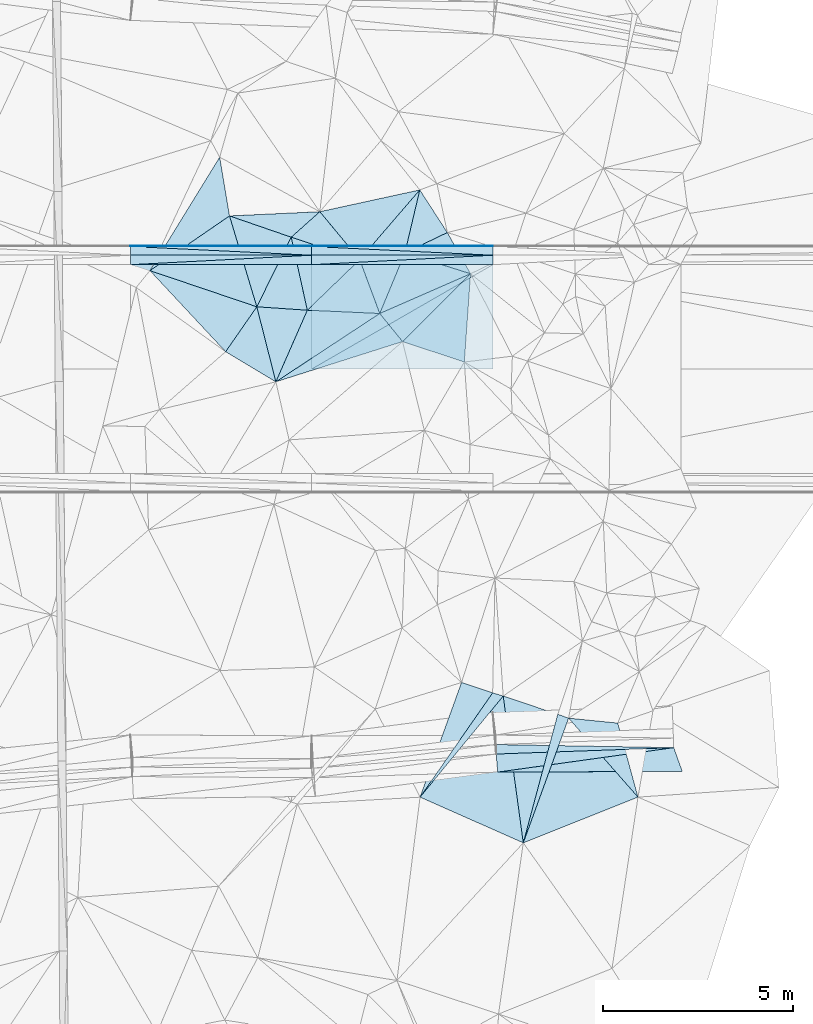
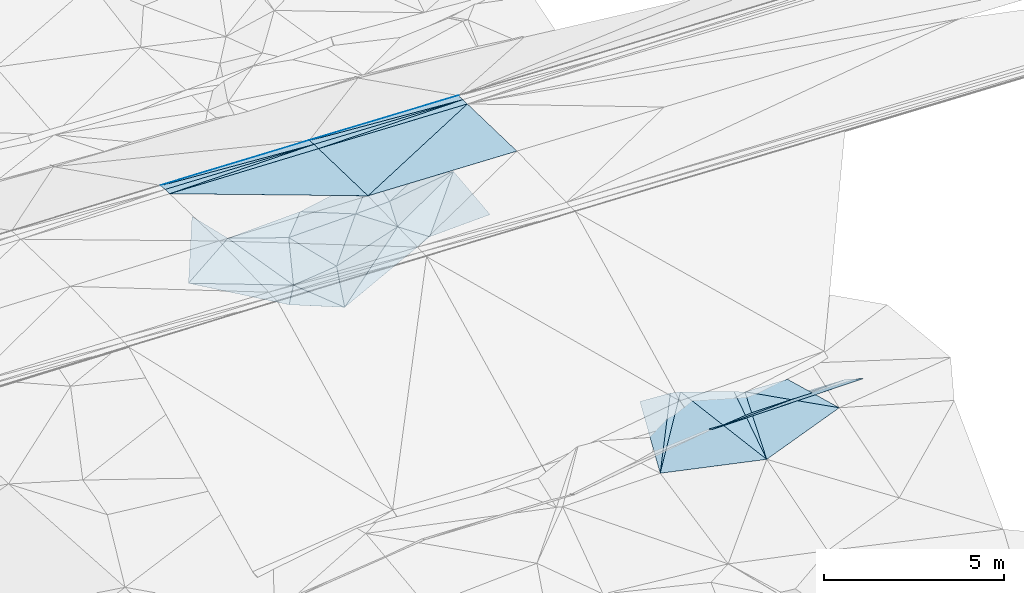
# One storey, part 104 of 275: 46 plates.
"""IFC2X3 building model written with IfcOpenShell, lengths in millimetres."""

from ifc_helpers import new_model, si_unit, frame, origin_with_axes, place, context, subcontext, project, spatial, polyline, outline, extrude, material, type_object, element, save


model = new_model("IFC2X3")

# Units and contexts
model_context = context("Model", 3, precision=1e-05, world=origin_with_axes())
body_context = subcontext(model_context, "Body", "Model", "MODEL_VIEW")
ifc_project = project(units=[si_unit("LENGTHUNIT", "METRE", prefix="MILLI"), si_unit("AREAUNIT", "SQUARE_METRE"), si_unit("VOLUMEUNIT", "CUBIC_METRE"), si_unit("MASSUNIT", "GRAM", prefix="KILO"), si_unit("TIMEUNIT", "SECOND"), si_unit("PLANEANGLEUNIT", "RADIAN"), si_unit("SOLIDANGLEUNIT", "STERADIAN"), si_unit("THERMODYNAMICTEMPERATUREUNIT", "DEGREE_CELSIUS"), si_unit("LUMINOUSINTENSITYUNIT", "LUMEN")], contexts=[model_context])

# Site, building, storey
site_placement = place(None, origin_with_axes())
site = spatial("IfcSite", under=ifc_project, at=site_placement, CompositionType="ELEMENT")
building_placement = place(site_placement, origin_with_axes())
building = spatial("IfcBuilding", under=site, at=building_placement, Name="Undefined", CompositionType="ELEMENT")
storey_placement = place(building_placement, origin_with_axes())
storey = spatial("IfcBuildingStorey", under=building, at=storey_placement, Name="Undefined", CompositionType="ELEMENT", Elevation=0.0)

# Plates
ifc_material = material()
plate_type_1 = type_object("IfcPlateType", PredefinedType="NOTDEFINED")
plate_1_placement = place(storey_placement, frame((-34157.7798886638, 63288.8349847427, 48159.3554211649), z_axis=(-0.0325349900325498, -0.0249770971322937, -0.999158455422575), x_axis=(-0.999470311448704, 5.72619769427513e-05, 0.0325437129672813)))
element("IfcPlate", 1, at=plate_1_placement, inside=storey, type_object=plate_type_1, material=ifc_material, Name="00_PR", context=body_context, shape_type="SweptSolid", body=[
    extrude(outline(polyline([(0.0, 0.0), (4774.68701171875, -1.00262695923448e-08), (-2.23709058761597, 2750.8583984375), (0.0, 0.0)])), frame((-8.85201319254618e-08, 2.18876761149539e-07, -0.5000001331573), z_axis=(0.0, 0.0, 1.0), x_axis=(1.0, 0.0, 0.0)), (0.0, 0.0, 1.0), 1.0),
])
plate_2_placement = place(storey_placement, frame((-38929.7788829464, 66039.1084148734, 48245.9914218387), z_axis=(-0.0325349900325498, -0.0249770971322937, -0.999158455422575), x_axis=(0.999470311737321, -5.73689731605573e-05, -0.0325437039149539)))
element("IfcPlate", 2, at=plate_2_placement, inside=storey, type_object=plate_type_1, material=ifc_material, Name="00_PR", context=body_context, shape_type="SweptSolid", body=[
    extrude(outline(polyline([(0.0, 0.0), (4774.685546875, -1.0550138540566e-08), (-2.23870348930359, 2750.85791015625), (0.0, 0.0)])), frame((-8.85201319254618e-08, 2.18876761149539e-07, -0.5000001331573), z_axis=(0.0, 0.0, 1.0), x_axis=(1.0, 0.0, 0.0)), (0.0, 0.0, 1.0), 1.0),
])
plate_3_placement = place(storey_placement, frame((-43701.9354299348, 66039.382331575, 48388.7053802406), z_axis=(-0.0298842901449347, -0.024979317513143, -0.999241193555946), x_axis=(0.999553126962381, -5.74589773414719e-05, -0.0298921909232467)))
element("IfcPlate", 3, at=plate_3_placement, inside=storey, type_object=plate_type_1, material=ifc_material, Name="00_PR", context=body_context, shape_type="SweptSolid", body=[
    extrude(outline(polyline([(0.0, 0.0), (4774.29150390625, 1.48138497024775e-08), (4772.2353515625, 2750.85791015625), (0.0, 0.0)])), frame((-8.85201319254618e-08, 2.18876761149539e-07, -0.5000001331573), z_axis=(0.0, 0.0, 1.0), x_axis=(1.0, 0.0, 0.0)), (0.0, 0.0, 1.0), 1.0),
])
plate_type_2 = type_object("IfcPlateType", PredefinedType="NOTDEFINED")
plate_4_placement = place(storey_placement, frame((-29391.4771002406, 53320.1885323765, 44802.106068537), z_axis=(-0.0159420009922025, 0.0032903428272256, -0.999867504346673), x_axis=(-0.999226396124038, -0.0360076280313883, 0.0158132859494789)))
element("IfcPlate", 4, at=plate_4_placement, inside=storey, type_object=plate_type_2, material=ifc_material, Name="00_PR", context=body_context, shape_type="SweptSolid", body=[
    extrude(outline(polyline([(0.0, 0.0), (4679.5458984375, -6.95581547915936e-09), (4674.77392578125, 250.001678466797), (0.0, 0.0)])), frame((-8.85201319254618e-08, 2.18876761149539e-07, -0.5000001331573), z_axis=(0.0, 0.0, 1.0), x_axis=(1.0, 0.0, 0.0)), (0.0, 0.0, 1.0), 1.0),
])
plate_5_placement = place(storey_placement, frame((-34157.6080068169, 66288.8350087851, 48084.3554223276), z_axis=(-0.0325349900325498, -0.0249770971322937, -0.999158455422575), x_axis=(-5.7277968073799e-05, -0.999687644772795, 0.0249921909375039)))
element("IfcPlate", 5, at=plate_5_placement, inside=storey, type_object=plate_type_2, material=ifc_material, Name="00_PR", context=body_context, shape_type="SweptSolid", body=[
    extrude(outline(polyline([(0.0, 0.0), (250.078109741211, 1.02591002359986e-09), (253.961563110352, 4774.68408203125), (0.0, 0.0)])), frame((-8.85201319254618e-08, 2.18876761149539e-07, -0.5000001331573), z_axis=(0.0, 0.0, 1.0), x_axis=(1.0, 0.0, 0.0)), (0.0, 0.0, 1.0), 1.0),
])
for number, where, z_axis, x_axis, name in (
    (6, (-38929.7632344316, 66289.1084149121, 48239.7413805011), (-0.0298842901449347, -0.024979317513143, -0.999241193555946), (-5.7277968073799e-05, -0.999687644772795, 0.0249921909375039), "00_PR"),
    (7, (-43701.9354299348, 66039.382331575, 48388.7053802406), (-0.0298842901449347, -0.024979317513143, -0.999241193555946), (5.72779774420735e-05, 0.999687644773175, -0.0249921909222736), "00_PR"),
):
    element("IfcPlate", number, at=place(storey_placement, frame(where, z_axis=z_axis, x_axis=x_axis)), inside=storey, type_object=plate_type_2, material=ifc_material, Name=name, context=body_context, shape_type="SweptSolid", body=[
        extrude(outline(polyline([(0.0, 0.0), (250.078109741211, 1.02591002359986e-09), (253.644332885742, 4774.2900390625), (0.0, 0.0)])), frame((-8.85201319254618e-08, 2.18876761149539e-07, -0.5000001331573), z_axis=(0.0, 0.0, 1.0), x_axis=(1.0, 0.0, 0.0)), (0.0, 0.0, 1.0), 1.0),
    ])
plate_6_placement = place(storey_placement, frame((-38929.7788829464, 66039.1084148734, 48245.9914218387), z_axis=(-0.0325349900325498, -0.0249770971322937, -0.999158455422575), x_axis=(5.72779774420735e-05, 0.999687644773175, -0.0249921909222736)))
element("IfcPlate", 8, at=plate_6_placement, inside=storey, type_object=plate_type_2, material=ifc_material, Name="00_PR", context=body_context, shape_type="SweptSolid", body=[
    extrude(outline(polyline([(0.0, 0.0), (250.078109741211, 1.02591002359986e-09), (253.961563110352, 4774.68408203125), (0.0, 0.0)])), frame((-8.85201319254618e-08, 2.18876761149539e-07, -0.5000001331573), z_axis=(0.0, 0.0, 1.0), x_axis=(1.0, 0.0, 0.0)), (0.0, 0.0, 1.0), 1.0),
])
plate_type_3 = type_object("IfcPlateType", PredefinedType="NOTDEFINED")
plate_7_placement = place(storey_placement, frame((-34157.5936662457, 66538.822543624, 48071.8558900314), z_axis=(-0.032506019804462, -0.0499086502594823, -0.998224666748798), x_axis=(-5.44309877651753e-05, -0.998752377894856, 0.0499368069327535)))
element("IfcPlate", 9, at=plate_7_placement, inside=storey, type_object=plate_type_3, material=ifc_material, Name="00_PR", context=body_context, shape_type="SweptSolid", body=[
    extrude(outline(polyline([(0.0, 0.0), (20.0253086090088, -9.45874489843845e-11), (27.770565032959, 4774.6796875), (0.0, 0.0)])), frame((-8.85201319254618e-08, 2.18876761149539e-07, -0.5000001331573), z_axis=(0.0, 0.0, 1.0), x_axis=(1.0, 0.0, 0.0)), (0.0, 0.0, 1.0), 1.0),
])
plate_8_placement = place(storey_placement, frame((-38929.7488949328, 66539.0959489802, 48227.2418485083), z_axis=(-0.029857778963741, -0.0499145954196307, -0.998307090127806), x_axis=(-7.46349832174646e-05, -0.998752262639263, 0.0499390859204745)))
element("IfcPlate", 10, at=plate_8_placement, inside=storey, type_object=plate_type_3, material=ifc_material, Name="00_PR", context=body_context, shape_type="SweptSolid", body=[
    extrude(outline(polyline([(0.0, 0.0), (20.0243949890137, 1.30967237055302e-10), (27.2349071502686, 4774.28564453125), (0.0, 0.0)])), frame((-8.85201319254618e-08, 2.18876761149539e-07, -0.5000001331573), z_axis=(0.0, 0.0, 1.0), x_axis=(1.0, 0.0, 0.0)), (0.0, 0.0, 1.0), 1.0),
])
plate_9_placement = place(storey_placement, frame((-38929.7517155213, 66519.0965410612, 48228.2418896468), z_axis=(-0.0325060109705526, -0.049910272192996, -0.998224585942664), x_axis=(7.46349675932083e-05, 0.998752262639191, -0.0499390859219244)))
element("IfcPlate", 11, at=plate_9_placement, inside=storey, type_object=plate_type_3, material=ifc_material, Name="00_PR", context=body_context, shape_type="SweptSolid", body=[
    extrude(outline(polyline([(0.0, 0.0), (20.0243949890137, 1.30967237055302e-10), (27.8673305511475, 4774.67919921875), (0.0, 0.0)])), frame((-8.85201319254618e-08, 2.18876761149539e-07, -0.5000001331573), z_axis=(0.0, 0.0, 1.0), x_axis=(1.0, 0.0, 0.0)), (0.0, 0.0, 1.0), 1.0),
])
plate_10_placement = place(storey_placement, frame((-43701.907858217, 66519.3695432309, 48370.9558479757), z_axis=(-0.0298577808993792, -0.049913563424443, -0.998307141668354), x_axis=(5.4430974321816e-05, 0.998752377894704, -0.0499368069357979)))
element("IfcPlate", 12, at=plate_10_placement, inside=storey, type_object=plate_type_3, material=ifc_material, Name="00_PR", context=body_context, shape_type="SweptSolid", body=[
    extrude(outline(polyline([(0.0, 0.0), (20.0253086090088, -9.45874489843845e-11), (27.1381683349609, 4774.2861328125), (0.0, 0.0)])), frame((-8.85201319254618e-08, 2.18876761149539e-07, -0.5000001331573), z_axis=(0.0, 0.0, 1.0), x_axis=(1.0, 0.0, 0.0)), (0.0, 0.0, 1.0), 1.0),
])
plate_type_4 = type_object("IfcPlateType", PredefinedType="NOTDEFINED")
plate_11_placement = place(storey_placement, frame((-39465.322057765, 66763.5367216038, 44979.52247614), z_axis=(0.293806885397551, 0.039903768433183, -0.955031519562481), x_axis=(0.915167614544208, -0.30017788860304, 0.269000878220287)))
element("IfcPlate", 13, at=plate_11_placement, inside=storey, type_object=plate_type_4, material=ifc_material, Name="00", context=body_context, shape_type="SweptSolid", body=[
    extrude(outline(polyline([(0.0, 0.0), (1970.25378417969, 7.39237293601036e-09), (978.40185546875, 1709.45300292969), (0.0, 0.0)])), frame((-8.85201319254618e-08, 2.18876761149539e-07, -0.5000001331573), z_axis=(0.0, 0.0, 1.0), x_axis=(1.0, 0.0, 0.0)), (0.0, 0.0, 1.0), 1.0),
])
plate_type_5 = type_object("IfcPlateType", PredefinedType="NOTDEFINED")
plate_12_placement = place(storey_placement, frame((-34157.5947566948, 66518.8222185734, 48072.8558900683), z_axis=(-0.032506019804462, -0.0499086502594823, -0.998224666748798), x_axis=(-5.74669840174811e-05, -0.998752333725473, 0.0499376869254844)))
element("IfcPlate", 14, at=plate_12_placement, inside=storey, type_object=plate_type_5, material=ifc_material, Name="00_PR", context=body_context, shape_type="SweptSolid", body=[
    extrude(outline(polyline([(0.0, 0.0), (230.287002563477, 1.30967237055302e-09), (7.75987958908081, 4774.6796875), (0.0, 0.0)])), frame((-8.85201319254618e-08, 2.18876761149539e-07, -0.5000001331573), z_axis=(0.0, 0.0, 1.0), x_axis=(1.0, 0.0, 0.0)), (0.0, 0.0, 1.0), 1.0),
])
plate_13_placement = place(storey_placement, frame((-38929.7503908106, 66519.0965395202, 48228.2418483309), z_axis=(-0.0298577808993792, -0.049913563424443, -0.998307141668354), x_axis=(-5.57099735653163e-05, -0.998752343725082, 0.0499374889242045)))
element("IfcPlate", 15, at=plate_13_placement, inside=storey, type_object=plate_type_5, material=ifc_material, Name="00_PR", context=body_context, shape_type="SweptSolid", body=[
    extrude(outline(polyline([(0.0, 0.0), (230.28791809082, 9.89530235528946e-10), (7.11997509002686, 4774.28564453125), (0.0, 0.0)])), frame((-8.85201319254618e-08, 2.18876761149539e-07, -0.5000001331573), z_axis=(0.0, 0.0, 1.0), x_axis=(1.0, 0.0, 0.0)), (0.0, 0.0, 1.0), 1.0),
])
plate_14_placement = place(storey_placement, frame((-38929.7632207879, 66289.0959472875, 48239.7418482499), z_axis=(-0.029857778963741, -0.0499145954196307, -0.998307090127806), x_axis=(-0.999553127145901, 5.73739658806301e-05, 0.0298921849498749)))
element("IfcPlate", 16, at=plate_14_placement, inside=storey, type_object=plate_type_5, material=ifc_material, Name="00_PR", context=body_context, shape_type="SweptSolid", body=[
    extrude(outline(polyline([(0.0, 0.0), (4774.29150390625, 1.48138497024775e-08), (4773.94775390625, 230.286743164063), (0.0, 0.0)])), frame((-8.85201319254618e-08, 2.18876761149539e-07, -0.5000001331573), z_axis=(0.0, 0.0, 1.0), x_axis=(1.0, 0.0, 0.0)), (0.0, 0.0, 1.0), 1.0),
])
plate_15_placement = place(storey_placement, frame((-34157.6079911386, 66288.8225438506, 48084.3558898405), z_axis=(-0.032506019804462, -0.0499086502594823, -0.998224666748798), x_axis=(-0.999470311448704, 5.72619769427513e-05, 0.0325437129672813)))
element("IfcPlate", 17, at=plate_15_placement, inside=storey, type_object=plate_type_5, material=ifc_material, Name="00_PR", context=body_context, shape_type="SweptSolid", body=[
    extrude(outline(polyline([(0.0, 0.0), (4774.685546875, -1.0550138540566e-08), (4774.3115234375, 230.287612915039), (0.0, 0.0)])), frame((-8.85201319254618e-08, 2.18876761149539e-07, -0.5000001331573), z_axis=(0.0, 0.0, 1.0), x_axis=(1.0, 0.0, 0.0)), (0.0, 0.0, 1.0), 1.0),
])
plate_type_6 = type_object("IfcPlateType", PredefinedType="NOTDEFINED")
plate_16_placement = place(storey_placement, frame((-37134.0617276006, 64754.7490815827, 45749.5141291698), z_axis=(0.101172713531729, 0.213333269144417, -0.971726812593325), x_axis=(0.626593428410044, -0.772332893522209, -0.104319590954717)))
element("IfcPlate", 18, at=plate_16_placement, inside=storey, type_object=plate_type_6, material=ifc_material, Name="00", context=body_context, shape_type="SweptSolid", body=[
    extrude(outline(polyline([(0.0, 0.0), (958.592712402344, -3.10683390125632e-09), (-253.183639526367, 3335.0859375), (0.0, 0.0)])), frame((-8.85201319254618e-08, 2.18876761149539e-07, -0.5000001331573), z_axis=(0.0, 0.0, 1.0), x_axis=(1.0, 0.0, 0.0)), (0.0, 0.0, 1.0), 1.0),
])
plate_type_7 = type_object("IfcPlateType", PredefinedType="NOTDEFINED")
plate_17_placement = place(storey_placement, frame((-39041.6970165728, 64840.6370034271, 45029.5074106867), z_axis=(0.171194040924551, 0.0121039060902566, -0.985162979313211), x_axis=(-0.983192751791021, 0.0664843543979101, -0.170034830096345)))
element("IfcPlate", 19, at=plate_17_placement, inside=storey, type_object=plate_type_7, material=ifc_material, Name="00", context=body_context, shape_type="SweptSolid", body=[
    extrude(outline(polyline([(0.0, 0.0), (1352.6640625, -8.65838956087828e-10), (552.908935546875, 1890.44750976563), (0.0, 0.0)])), frame((-8.85201319254618e-08, 2.18876761149539e-07, -0.5000001331573), z_axis=(0.0, 0.0, 1.0), x_axis=(1.0, 0.0, 0.0)), (0.0, 0.0, 1.0), 1.0),
])
plate_type_8 = type_object("IfcPlateType", PredefinedType="NOTDEFINED")
plate_18_placement = place(storey_placement, frame((-29167.6874820426, 52694.5953867692, 45130.9110832411), z_axis=(0.00477687815413456, -0.463970579021258, -0.885837729630986), x_axis=(-0.999986871906384, -0.00385876503807919, -0.0033713420572529)))
element("IfcPlate", 20, at=plate_18_placement, inside=storey, type_object=plate_type_8, material=ifc_material, Name="00_PR", context=body_context, shape_type="SweptSolid", body=[
    extrude(outline(polyline([(0.0, 0.0), (4860.37939453125, 3.18323145620525e-09), (222.471527099609, 706.918212890625), (0.0, 0.0)])), frame((-8.85201319254618e-08, 2.18876761149539e-07, -0.5000001331573), z_axis=(0.0, 0.0, 1.0), x_axis=(1.0, 0.0, 0.0)), (0.0, 0.0, 1.0), 1.0),
])
plate_type_9 = type_object("IfcPlateType", PredefinedType="NOTDEFINED")
plate_19_placement = place(storey_placement, frame((-34067.3940995751, 53151.4635738362, 44876.1579650165), z_axis=(0.00199168775112642, -0.447915840254046, -0.894073505495725), x_axis=(0.999226396123554, 0.0360076280467487, -0.0158132859451127)))
element("IfcPlate", 21, at=plate_19_placement, inside=storey, type_object=plate_type_9, material=ifc_material, Name="00_PR", context=body_context, shape_type="SweptSolid", body=[
    extrude(outline(polyline([(0.0, 0.0), (4679.5458984375, -6.95581547915936e-09), (18.4640045166016, 533.13916015625), (0.0, 0.0)])), frame((-8.85201319254618e-08, 2.18876761149539e-07, -0.5000001331573), z_axis=(0.0, 0.0, 1.0), x_axis=(1.0, 0.0, 0.0)), (0.0, 0.0, 1.0), 1.0),
])
plate_type_10 = type_object("IfcPlateType", PredefinedType="NOTDEFINED")
plate_20_placement = place(storey_placement, frame((-39465.4762776958, 66763.6734021324, 44979.5252156716), z_axis=(-0.0146321569144532, 0.313264887365868, -0.949553058195107), x_axis=(-0.938381540112912, 0.323640270384909, 0.121231433879594)))
element("IfcPlate", 22, at=plate_20_placement, inside=storey, type_object=plate_type_10, material=ifc_material, Name="00", context=body_context, shape_type="SweptSolid", body=[
    extrude(outline(polyline([(0.0, 0.0), (1732.22399902344, -5.41331246495247e-09), (-463.450439453125, 920.333435058594), (0.0, 0.0)])), frame((-8.85201319254618e-08, 2.18876761149539e-07, -0.5000001331573), z_axis=(0.0, 0.0, 1.0), x_axis=(1.0, 0.0, 0.0)), (0.0, 0.0, 1.0), 1.0),
])
plate_type_11 = type_object("IfcPlateType", PredefinedType="NOTDEFINED")
plate_21_placement = place(storey_placement, frame((-40371.7733601256, 64930.623760579, 44799.5076254806), z_axis=(-0.122535614064306, 0.123628299906102, -0.984734008120066), x_axis=(-0.935610165082989, 0.316613192369293, 0.15617203786564)))
element("IfcPlate", 23, at=plate_21_placement, inside=storey, type_object=plate_type_11, material=ifc_material, Name="00", context=body_context, shape_type="SweptSolid", body=[
    extrude(outline(polyline([(0.0, 0.0), (3009.50170898438, 3.7325662560761e-09), (1491.67553710938, 2042.91552734375), (0.0, 0.0)])), frame((-8.85201319254618e-08, 2.18876761149539e-07, -0.5000001331573), z_axis=(0.0, 0.0, 1.0), x_axis=(1.0, 0.0, 0.0)), (0.0, 0.0, 1.0), 1.0),
])
plate_type_12 = type_object("IfcPlateType", PredefinedType="NOTDEFINED")
plate_22_placement = place(storey_placement, frame((-30332.91578401, 52016.9445108403, 44959.5003651347), z_axis=(0.0381742456968222, -0.00491207035176491, -0.999259024743003), x_axis=(-0.659763180588045, 0.750917818761661, -0.0288959340838199)))
element("IfcPlate", 24, at=plate_22_placement, inside=storey, type_object=plate_type_12, material=ifc_material, Name="00", context=body_context, shape_type="SweptSolid", body=[
    extrude(outline(polyline([(0.0, 0.0), (2768.5556640625, -6.79938239045441e-09), (1818.05993652344, 886.317138671875), (0.0, 0.0)])), frame((-8.85201319254618e-08, 2.18876761149539e-07, -0.5000001331573), z_axis=(0.0, 0.0, 1.0), x_axis=(1.0, 0.0, 0.0)), (0.0, 0.0, 1.0), 1.0),
])
plate_type_13 = type_object("IfcPlateType", PredefinedType="NOTDEFINED")
plate_23_placement = place(storey_placement, frame((-36072.6823246314, 52016.0883331825, 44749.5035120519), z_axis=(0.0345548503179878, 0.113270658752793, -0.992963101119679), x_axis=(0.567556370621511, 0.815572861526726, 0.112785964144685)))
element("IfcPlate", 25, at=plate_23_placement, inside=storey, type_object=plate_type_13, material=ifc_material, Name="00", context=body_context, shape_type="SweptSolid", body=[
    extrude(outline(polyline([(0.0, 0.0), (3369.21362304688, -2.16095941141248e-09), (3457.83959960938, 276.84912109375), (0.0, 0.0)])), frame((-8.85201319254618e-08, 2.18876761149539e-07, -0.5000001331573), z_axis=(0.0, 0.0, 1.0), x_axis=(1.0, 0.0, 0.0)), (0.0, 0.0, 1.0), 1.0),
])
plate_type_14 = type_object("IfcPlateType", PredefinedType="NOTDEFINED")
plate_24_placement = place(storey_placement, frame((-33353.9993594993, 50812.5902158991, 44999.5049674702), z_axis=(-0.139976324205643, 0.0141544445025967, -0.990053675495778), x_axis=(-0.135356888571792, 0.990237350686044, 0.0332941740015962)))
element("IfcPlate", 26, at=plate_24_placement, inside=storey, type_object=plate_type_14, material=ifc_material, Name="00", context=body_context, shape_type="SweptSolid", body=[
    extrude(outline(polyline([(0.0, 0.0), (3904.58715820313, -1.91721483133733e-09), (3227.76782226563, 1371.42834472656), (0.0, 0.0)])), frame((-8.85201319254618e-08, 2.18876761149539e-07, -0.5000001331573), z_axis=(0.0, 0.0, 1.0), x_axis=(1.0, 0.0, 0.0)), (0.0, 0.0, 1.0), 1.0),
])
plate_type_15 = type_object("IfcPlateType", PredefinedType="NOTDEFINED")
plate_25_placement = place(storey_placement, frame((-32159.5251300935, 54095.8861392331, 44879.5003391267), z_axis=(0.00155437285779837, -0.0370886127852513, -0.999310771845618), x_axis=(0.659763180591049, -0.750917818758965, 0.028895934085301)))
element("IfcPlate", 27, at=plate_25_placement, inside=storey, type_object=plate_type_15, material=ifc_material, Name="00", context=body_context, shape_type="SweptSolid", body=[
    extrude(outline(polyline([(0.0, 0.0), (2768.5556640625, -6.79938239045441e-09), (1680.94873046875, 3065.22607421875), (0.0, 0.0)])), frame((-8.85201319254618e-08, 2.18876761149539e-07, -0.5000001331573), z_axis=(0.0, 0.0, 1.0), x_axis=(1.0, 0.0, 0.0)), (0.0, 0.0, 1.0), 1.0),
])
plate_type_16 = type_object("IfcPlateType", PredefinedType="NOTDEFINED")
plate_26_placement = place(storey_placement, frame((-36072.6035157718, 52016.0326883032, 44749.5093138878), z_axis=(0.19217188104437, 0.00198042085265789, -0.98135928490493), x_axis=(0.339389969301832, 0.938158980840767, 0.0683533130514863)))
element("IfcPlate", 28, at=plate_26_placement, inside=storey, type_object=plate_type_16, material=ifc_material, Name="00", context=body_context, shape_type="SweptSolid", body=[
    extrude(outline(polyline([(0.0, 0.0), (3218.57104492188, -7.78527464717627e-09), (3252.8720703125, 877.737670898438), (0.0, 0.0)])), frame((-8.85201319254618e-08, 2.18876761149539e-07, -0.5000001331573), z_axis=(0.0, 0.0, 1.0), x_axis=(1.0, 0.0, 0.0)), (0.0, 0.0, 1.0), 1.0),
])
plate_type_17 = type_object("IfcPlateType", PredefinedType="NOTDEFINED")
plate_27_placement = place(storey_placement, frame((-40371.7893798332, 64930.4758500376, 44799.5135637017), z_axis=(-0.154572152628233, -0.172195814210926, -0.972859728429598), x_axis=(0.244006482554707, -0.960843945797353, 0.13130022199468)))
element("IfcPlate", 29, at=plate_27_placement, inside=storey, type_object=plate_type_17, material=ifc_material, Name="00", context=body_context, shape_type="SweptSolid", body=[
    extrude(outline(polyline([(0.0, 0.0), (2056.35595703125, 7.93443177826703e-09), (981.104431152344, 1108.34741210938), (0.0, 0.0)])), frame((-8.85201319254618e-08, 2.18876761149539e-07, -0.5000001331573), z_axis=(0.0, 0.0, 1.0), x_axis=(1.0, 0.0, 0.0)), (0.0, 0.0, 1.0), 1.0),
])
plate_type_18 = type_object("IfcPlateType", PredefinedType="NOTDEFINED")
plate_28_placement = place(storey_placement, frame((-34742.8185437786, 65800.6290296957, 46159.5611968916), z_axis=(0.251383005574127, -0.408199012869243, -0.877599082953654), x_axis=(-0.88097953881355, 0.279017572494095, -0.38213119007923)))
element("IfcPlate", 30, at=plate_28_placement, inside=storey, type_object=plate_type_18, material=ifc_material, Name="00", context=body_context, shape_type="SweptSolid", body=[
    extrude(outline(polyline([(0.0, 0.0), (1962.6767578125, 7.42875272408128e-09), (1101.14929199219, 895.47216796875), (0.0, 0.0)])), frame((-8.85201319254618e-08, 2.18876761149539e-07, -0.5000001331573), z_axis=(0.0, 0.0, 1.0), x_axis=(1.0, 0.0, 0.0)), (0.0, 0.0, 1.0), 1.0),
])
plate_type_19 = type_object("IfcPlateType", PredefinedType="NOTDEFINED")
plate_29_placement = place(storey_placement, frame((-41193.5248315085, 63747.1967046008, 45139.5154944002), z_axis=(-0.207259491568794, -0.13449841451381, -0.968996222721181), x_axis=(-0.681694307077067, 0.730286021160382, 0.0444432109152353)))
element("IfcPlate", 31, at=plate_29_placement, inside=storey, type_object=plate_type_19, material=ifc_material, Name="00", context=body_context, shape_type="SweptSolid", body=[
    extrude(outline(polyline([(0.0, 0.0), (2925.08129882813, -9.10222297534347e-09), (288.880859375, 1451.73962402344), (0.0, 0.0)])), frame((-8.85201319254618e-08, 2.18876761149539e-07, -0.5000001331573), z_axis=(0.0, 0.0, 1.0), x_axis=(1.0, 0.0, 0.0)), (0.0, 0.0, 1.0), 1.0),
])
plate_type_20 = type_object("IfcPlateType", PredefinedType="NOTDEFINED")
plate_30_placement = place(storey_placement, frame((-34742.9036838875, 65800.9319694049, 46159.5115363184), z_axis=(0.0810159321854727, 0.197680567489853, -0.976912898865098), x_axis=(-0.69392711559529, -0.69238587445385, -0.197653634164358)))
element("IfcPlate", 32, at=plate_30_placement, inside=storey, type_object=plate_type_20, material=ifc_material, Name="00", context=body_context, shape_type="SweptSolid", body=[
    extrude(outline(polyline([(0.0, 0.0), (2580.27124023438, -1.27038219943643e-08), (2464.7021484375, 951.600646972656), (0.0, 0.0)])), frame((-8.85201319254618e-08, 2.18876761149539e-07, -0.5000001331573), z_axis=(0.0, 0.0, 1.0), x_axis=(1.0, 0.0, 0.0)), (0.0, 0.0, 1.0), 1.0),
])
plate_type_21 = type_object("IfcPlateType", PredefinedType="NOTDEFINED")
plate_31_placement = place(storey_placement, frame((-33353.9963761039, 50812.5894061758, 44999.5045440113), z_axis=(-0.134009667389631, 0.0125341122526704, -0.990900754402861), x_axis=(0.258987301334494, 0.965611320841019, -0.0228112869242131)))
element("IfcPlate", 33, at=plate_31_placement, inside=storey, type_object=plate_type_21, material=ifc_material, Name="00", context=body_context, shape_type="SweptSolid", body=[
    extrude(outline(polyline([(0.0, 0.0), (3507.03588867188, 7.27595761418343e-12), (3482.48510742188, 305.773223876953), (0.0, 0.0)])), frame((-8.85201319254618e-08, 2.18876761149539e-07, -0.5000001331573), z_axis=(0.0, 0.0, 1.0), x_axis=(1.0, 0.0, 0.0)), (0.0, 0.0, 1.0), 1.0),
])
plate_type_22 = type_object("IfcPlateType", PredefinedType="NOTDEFINED")
plate_32_placement = place(storey_placement, frame((-34742.7977471638, 65800.8228000014, 46159.5220319244), z_axis=(0.292890950588697, -0.020658111424363, -0.955922660833829), x_axis=(-0.0703569644010126, -0.9975218782364, -7.85632077593133e-11)))
element("IfcPlate", 34, at=plate_32_placement, inside=storey, type_object=plate_type_22, material=ifc_material, Name="00", context=body_context, shape_type="SweptSolid", body=[
    extrude(outline(polyline([(0.0, 0.0), (2330.60083007813, 1.24091457109898e-08), (1908.09167480469, 1736.94738769531), (0.0, 0.0)])), frame((-8.85201319254618e-08, 2.18876761149539e-07, -0.5000001331573), z_axis=(0.0, 0.0, 1.0), x_axis=(1.0, 0.0, 0.0)), (0.0, 0.0, 1.0), 1.0),
])
plate_type_23 = type_object("IfcPlateType", PredefinedType="NOTDEFINED")
plate_33_placement = place(storey_placement, frame((-36079.9162576811, 68008.7301172696, 45169.5051387358), z_axis=(-0.0641952987838035, -0.127899344550873, -0.989707391746427), x_axis=(-0.227614412359446, -0.96373509076665, 0.139306690834506)))
element("IfcPlate", 35, at=plate_33_placement, inside=storey, type_object=plate_type_23, material=ifc_material, Name="00", context=body_context, shape_type="SweptSolid", body=[
    extrude(outline(polyline([(0.0, 0.0), (1722.81750488281, -1.01863406598568e-08), (2177.65380859375, 1118.53649902344), (0.0, 0.0)])), frame((-8.85201319254618e-08, 2.18876761149539e-07, -0.5000001331573), z_axis=(0.0, 0.0, 1.0), x_axis=(1.0, 0.0, 0.0)), (0.0, 0.0, 1.0), 1.0),
])
plate_type_24 = type_object("IfcPlateType", PredefinedType="NOTDEFINED")
plate_34_placement = place(storey_placement, frame((-37662.1805479972, 66172.0765096947, 45509.5321728913), z_axis=(0.351902866261951, -0.027276294479976, -0.935639020389843), x_axis=(0.344896855396158, -0.925468333417019, 0.156698828904901)))
element("IfcPlate", 36, at=plate_34_placement, inside=storey, type_object=plate_type_24, material=ifc_material, Name="00", context=body_context, shape_type="SweptSolid", body=[
    extrude(outline(polyline([(0.0, 0.0), (1531.60046386719, -7.11952452547848e-09), (681.248168945313, 1855.23608398438), (0.0, 0.0)])), frame((-8.85201319254618e-08, 2.18876761149539e-07, -0.5000001331573), z_axis=(0.0, 0.0, 1.0), x_axis=(1.0, 0.0, 0.0)), (0.0, 0.0, 1.0), 1.0),
])
plate_type_25 = type_object("IfcPlateType", PredefinedType="NOTDEFINED")
plate_35_placement = place(storey_placement, frame((-39869.8661039914, 62954.6783982586, 45069.5089094999), z_axis=(0.163590858356273, -0.0926699919659817, -0.982166128336384), x_axis=(-0.244006482571149, 0.960843945796021, -0.131300221973875)))
element("IfcPlate", 37, at=plate_35_placement, inside=storey, type_object=plate_type_25, material=ifc_material, Name="00", context=body_context, shape_type="SweptSolid", body=[
    extrude(outline(polyline([(0.0, 0.0), (2056.35595703125, 7.93443177826703e-09), (1615.23583984375, 1278.71533203125), (0.0, 0.0)])), frame((-8.85201319254618e-08, 2.18876761149539e-07, -0.5000001331573), z_axis=(0.0, 0.0, 1.0), x_axis=(1.0, 0.0, 0.0)), (0.0, 0.0, 1.0), 1.0),
])
plate_type_26 = type_object("IfcPlateType", PredefinedType="NOTDEFINED")
plate_36_placement = place(storey_placement, frame((-37662.2172807345, 66172.0842719533, 45509.5198011016), z_axis=(0.27843706376372, -0.0117502942112781, -0.960382596733503), x_axis=(-0.915167614542924, 0.300177888604147, -0.269000878223418)))
element("IfcPlate", 38, at=plate_36_placement, inside=storey, type_object=plate_type_26, material=ifc_material, Name="00", context=body_context, shape_type="SweptSolid", body=[
    extrude(outline(polyline([(0.0, 0.0), (1970.25378417969, 7.39237293601036e-09), (1426.56750488281, 875.331481933594), (0.0, 0.0)])), frame((-8.85201319254618e-08, 2.18876761149539e-07, -0.5000001331573), z_axis=(0.0, 0.0, 1.0), x_axis=(1.0, 0.0, 0.0)), (0.0, 0.0, 1.0), 1.0),
])
plate_type_27 = type_object("IfcPlateType", PredefinedType="NOTDEFINED")
plate_37_placement = place(storey_placement, frame((-33882.3856973138, 54679.0754676151, 45129.5037877816), z_axis=(0.112853827371428, 0.0487934616096411, -0.992412823250369), x_axis=(0.13535688857005, -0.990237350686275, -0.0332941740018101)))
element("IfcPlate", 39, at=plate_37_placement, inside=storey, type_object=plate_type_27, material=ifc_material, Name="00", context=body_context, shape_type="SweptSolid", body=[
    extrude(outline(polyline([(0.0, 0.0), (3904.58715820313, -1.91721483133733e-09), (2353.20654296875, 2548.669921875), (0.0, 0.0)])), frame((-8.85201319254618e-08, 2.18876761149539e-07, -0.5000001331573), z_axis=(0.0, 0.0, 1.0), x_axis=(1.0, 0.0, 0.0)), (0.0, 0.0, 1.0), 1.0),
])
plate_type_28 = type_object("IfcPlateType", PredefinedType="NOTDEFINED")
plate_38_placement = place(storey_placement, frame((-41348.8566852463, 68871.9964506134, 45079.5012165891), z_axis=(0.00955651552640449, -0.0692978004808148, -0.997550243275753), x_axis=(0.163948729622379, -0.98398736520303, 0.069926240968667)))
element("IfcPlate", 40, at=plate_38_placement, inside=storey, type_object=plate_type_28, material=ifc_material, Name="00", context=body_context, shape_type="SweptSolid", body=[
    extrude(outline(polyline([(0.0, 0.0), (1573.08618164063, 3.45971784554422e-09), (2652.6201171875, 2304.75732421875), (0.0, 0.0)])), frame((-8.85201319254618e-08, 2.18876761149539e-07, -0.5000001331573), z_axis=(0.0, 0.0, 1.0), x_axis=(1.0, 0.0, 0.0)), (0.0, 0.0, 1.0), 1.0),
])
plate_39_placement = place(storey_placement, frame((-37134.1397014805, 64754.5491630343, 45749.5095288498), z_axis=(-0.054774829181288, -0.186501998866849, -0.98092646131442), x_axis=(-0.344896855399873, 0.925468333415551, -0.156698828905392)))
element("IfcPlate", 41, at=plate_39_placement, inside=storey, type_object=plate_type_28, material=ifc_material, Name="00", context=body_context, shape_type="SweptSolid", body=[
    extrude(outline(polyline([(0.0, 0.0), (1531.60046386719, -7.11952452547848e-09), (1299.94738769531, 1185.04724121094), (0.0, 0.0)])), frame((-8.85201319254618e-08, 2.18876761149539e-07, -0.5000001331573), z_axis=(0.0, 0.0, 1.0), x_axis=(1.0, 0.0, 0.0)), (0.0, 0.0, 1.0), 1.0),
])
plate_type_29 = type_object("IfcPlateType", PredefinedType="NOTDEFINED")
plate_40_placement = place(storey_placement, frame((-39869.7772449635, 62954.639989103, 45069.5377195278), z_axis=(0.341305625723826, -0.169488430652917, -0.924545370289679), x_axis=(0.40199830057579, 0.915434526544818, -0.0194163318843054)))
element("IfcPlate", 42, at=plate_40_placement, inside=storey, type_object=plate_type_29, material=ifc_material, Name="00", context=body_context, shape_type="SweptSolid", body=[
    extrude(outline(polyline([(0.0, 0.0), (2060.12133789063, 4.40923031419516e-09), (2734.30493164063, 1926.259765625), (0.0, 0.0)])), frame((-8.85201319254618e-08, 2.18876761149539e-07, -0.5000001331573), z_axis=(0.0, 0.0, 1.0), x_axis=(1.0, 0.0, 0.0)), (0.0, 0.0, 1.0), 1.0),
])
plate_type_30 = type_object("IfcPlateType", PredefinedType="NOTDEFINED")
plate_41_placement = place(storey_placement, frame((-36079.8115524735, 68008.7065358194, 45169.5130968512), z_axis=(0.145214263220533, -0.175056809895706, -0.973790496496272), x_axis=(0.528979163242837, -0.818006491380981, 0.225934558918031)))
element("IfcPlate", 43, at=plate_41_placement, inside=storey, type_object=plate_type_30, material=ifc_material, Name="00", context=body_context, shape_type="SweptSolid", body=[
    extrude(outline(polyline([(0.0, 0.0), (1372.07873535156, 6.75026967655867e-09), (1204.96008300781, 1231.3291015625), (0.0, 0.0)])), frame((-8.85201319254618e-08, 2.18876761149539e-07, -0.5000001331573), z_axis=(0.0, 0.0, 1.0), x_axis=(1.0, 0.0, 0.0)), (0.0, 0.0, 1.0), 1.0),
])
plate_type_31 = type_object("IfcPlateType", PredefinedType="NOTDEFINED")
plate_42_placement = place(storey_placement, frame((-37662.3368378077, 66171.9828779562, 45509.5120301864), z_axis=(0.0393238614319655, -0.214538102921209, -0.975923683654131), x_axis=(-0.627609963522295, 0.7546862107559, -0.191192199062735)))
element("IfcPlate", 44, at=plate_42_placement, inside=storey, type_object=plate_type_31, material=ifc_material, Name="00", context=body_context, shape_type="SweptSolid", body=[
    extrude(outline(polyline([(0.0, 0.0), (1673.70849609375, -7.71251507103443e-10), (457.965057373047, 2404.90502929688), (0.0, 0.0)])), frame((-8.85201319254618e-08, 2.18876761149539e-07, -0.5000001331573), z_axis=(0.0, 0.0, 1.0), x_axis=(1.0, 0.0, 0.0)), (0.0, 0.0, 1.0), 1.0),
])
plate_type_32 = type_object("IfcPlateType", PredefinedType="NOTDEFINED")
plate_43_placement = place(storey_placement, frame((-41090.9961925648, 67324.2025707657, 45189.5063209228), z_axis=(-0.0804055699276251, 0.136712907317651, -0.987342152091852), x_axis=(0.938381540112263, -0.323640270385319, -0.121231433883521)))
element("IfcPlate", 45, at=plate_43_placement, inside=storey, type_object=plate_type_32, material=ifc_material, Name="00", context=body_context, shape_type="SweptSolid", body=[
    extrude(outline(polyline([(0.0, 0.0), (1732.22399902344, -5.41331246495247e-09), (1496.86181640625, 2039.11865234375), (0.0, 0.0)])), frame((-8.85201319254618e-08, 2.18876761149539e-07, -0.5000001331573), z_axis=(0.0, 0.0, 1.0), x_axis=(1.0, 0.0, 0.0)), (0.0, 0.0, 1.0), 1.0),
])
plate_type_33 = type_object("IfcPlateType", PredefinedType="NOTDEFINED")
plate_44_placement = place(storey_placement, frame((-37133.9661594886, 64754.4853557391, 45749.5483613662), z_axis=(0.292311344055945, -0.31411846693208, -0.903262789485124), x_axis=(0.376394166506892, 0.906072408320558, -0.193287925902698)))
element("IfcPlate", 46, at=plate_44_placement, inside=storey, type_object=plate_type_33, material=ifc_material, Name="00", context=body_context, shape_type="SweptSolid", body=[
    extrude(outline(polyline([(0.0, 0.0), (1759.03381347656, 1.04046193882823e-09), (1768.6982421875, 1962.65295410156), (0.0, 0.0)])), frame((-8.85201319254618e-08, 2.18876761149539e-07, -0.5000001331573), z_axis=(0.0, 0.0, 1.0), x_axis=(1.0, 0.0, 0.0)), (0.0, 0.0, 1.0), 1.0),
])

save(model, "model.ifc")
